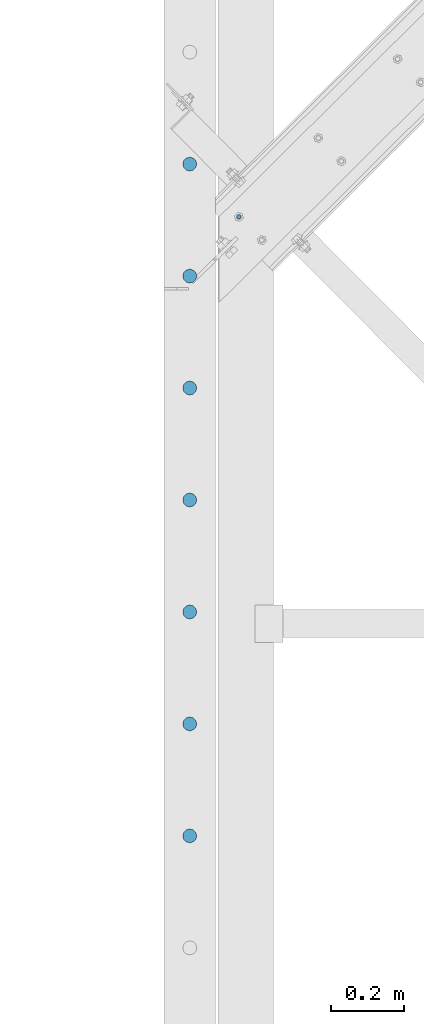
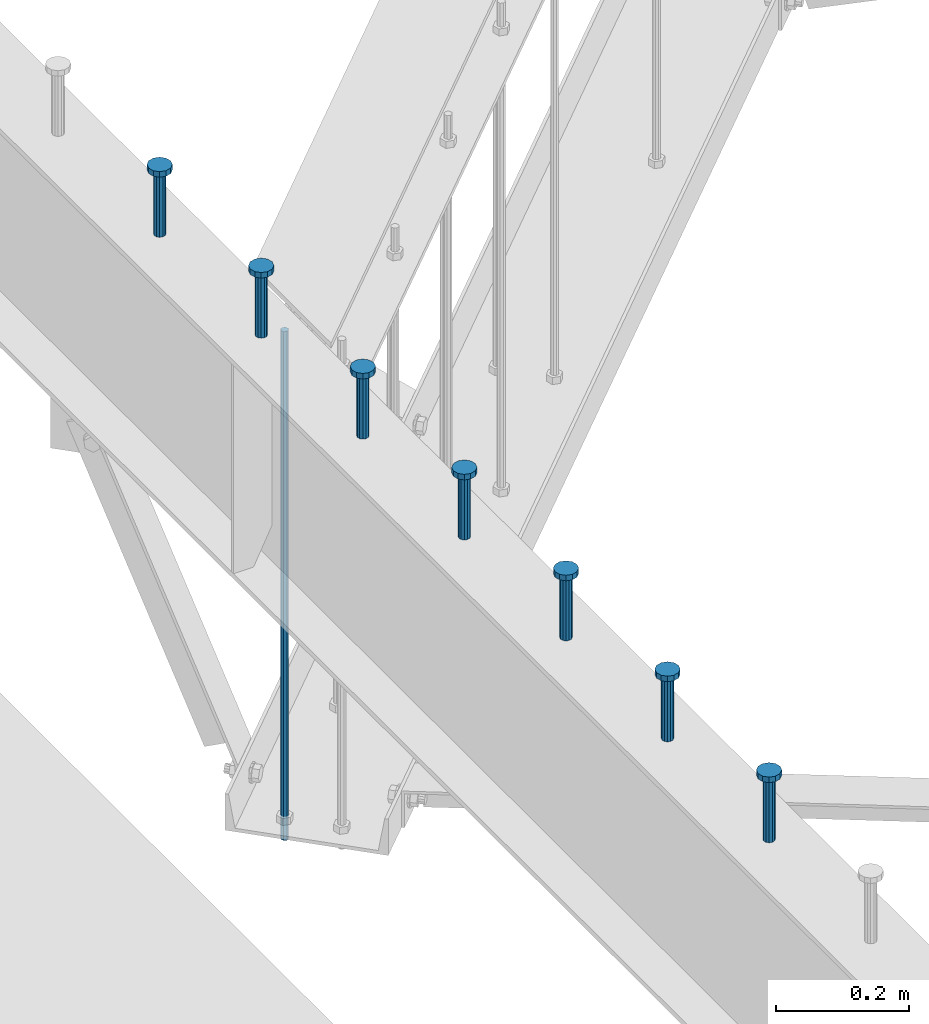
# One storey, part 197 of 975: 8 columns.
"""IFC2X3 building model written with IfcOpenShell, lengths in millimetres."""

from ifc_helpers import new_model, si_unit, frame, origin_with_axes, place, context, subcontext, project, spatial, faceted_brep, material, type_object, element, save


model = new_model("IFC2X3")

# Units and contexts
model_context = context("Model", 3, precision=1e-05, world=origin_with_axes())
body_context = subcontext(model_context, "Body", "Model", "MODEL_VIEW")
ifc_project = project(units=[si_unit("LENGTHUNIT", "METRE", prefix="MILLI"), si_unit("AREAUNIT", "SQUARE_METRE"), si_unit("VOLUMEUNIT", "CUBIC_METRE"), si_unit("MASSUNIT", "GRAM", prefix="KILO"), si_unit("TIMEUNIT", "SECOND"), si_unit("PLANEANGLEUNIT", "RADIAN"), si_unit("SOLIDANGLEUNIT", "STERADIAN"), si_unit("THERMODYNAMICTEMPERATUREUNIT", "DEGREE_CELSIUS"), si_unit("LUMINOUSINTENSITYUNIT", "LUMEN")], contexts=[model_context])

# Site, building, storey
site_placement = place(None, origin_with_axes())
site = spatial("IfcSite", under=ifc_project, at=site_placement, CompositionType="ELEMENT")
building_placement = place(site_placement, origin_with_axes())
building = spatial("IfcBuilding", under=site, at=building_placement, Name="Undefined", CompositionType="ELEMENT")
storey_placement = place(building_placement, origin_with_axes())
storey = spatial("IfcBuildingStorey", under=building, at=storey_placement, Name="Undefined", CompositionType="ELEMENT", Elevation=0.0)

# Columns
ifc_material_1 = material(Name="STEEL/A36")
column_type_1 = type_object("IfcColumnType", PredefinedType="NOTDEFINED")
column_1_placement = place(storey_placement, frame((23704.8451120013, 9911.53748289122, 2870.2), z_axis=(-0.705007718837806, 0.709199630836842, 0.0), x_axis=(0.0, 0.0, 1.0)))
element("IfcColumn", 1, at=column_1_placement, inside=storey, type_object=column_type_1, material=ifc_material_1, Name="ALL-THREAD ROD", context=body_context, shape_type="Brep", body=[
    faceted_brep([(0.0, -6.34999999998763, -3.63797880709171e-12), (0.0, -4.49012806052269, -4.49012806054634), (931.8625, -4.49012806052269, -4.49012806054634), (931.8625, -6.34999999998763, -3.63797880709171e-12), (0.0, 7.27595761418343e-12, -6.35000000000764), (931.8625, 7.27595761418343e-12, -6.35000000000764), (0.0, 4.49012806053724, -4.49012806053906), (931.8625, 4.49012806053724, -4.49012806053906), (0.0, 6.34999999999491, 5.45696821063757e-12), (931.8625, 6.34999999999491, 5.45696821063757e-12), (0.0, 4.49012806052633, 4.49012806054634), (931.8625, 4.49012806052633, 4.49012806054634), (0.0, 0.0, 6.35000000000764), (931.8625, 0.0, 6.35000000000764), (0.0, -4.49012806053361, 4.49012806053543), (931.8625, -4.49012806053361, 4.49012806053543)], [[[0, 1, 2, 3]], [[1, 4, 5, 2]], [[4, 6, 7, 5]], [[6, 8, 9, 7]], [[8, 10, 11, 9]], [[10, 12, 13, 11]], [[12, 14, 15, 13]], [[14, 0, 3, 15]], [[5, 7, 9, 11, 13, 15, 3, 2]], [[14, 12, 10, 8, 6, 4, 1, 0]]]),
])
ifc_material_2 = material(Name="STEEL/A108")
column_type_2 = type_object("IfcColumnType", Name="STUD_3/4-DIA", PredefinedType="NOTDEFINED")
column_2_placement = place(storey_placement, frame((23571.2662714101, 10055.225, 3937.0), z_axis=(0.0, 1.0, 0.0), x_axis=(0.0, 0.0, 1.0)))
element("IfcColumn", 2, at=column_2_placement, inside=storey, type_object=column_type_2, material=ifc_material_2, ObjectType="STUD_3/4-DIA", context=body_context, shape_type="Brep", body=[
    faceted_brep([(0.0, -9.52000045776367, 0.0), (0.0, -8.25, -4.76000022888184), (115.57, -8.25, -4.76000022888184), (115.57, -9.52000045776367, 0.0), (0.0, -4.76000022888184, -8.25), (115.57, -4.76000022888184, -8.25), (0.0, 0.0, -9.52000045776367), (115.57, 0.0, -9.52000045776367), (0.0, 4.76000022888184, -8.25), (115.57, 4.76000022888184, -8.25), (0.0, 8.25, -4.76000022888184), (115.57, 8.25, -4.76000022888184), (0.0, 9.52000045776367, 0.0), (115.57, 9.52000045776367, 0.0), (0.0, 8.25, 4.76000022888184), (115.57, 8.25, 4.76000022888184), (0.0, 4.76000022888184, 8.25), (115.57, 4.76000022888184, 8.25), (0.0, 0.0, 9.52000045776367), (115.57, 0.0, 9.52000045776367), (0.0, -4.76000022888184, 8.25), (115.57, -4.76000022888184, 8.25), (0.0, -8.25, 4.76000022888184), (115.57, -8.25, 4.76000022888184), (116.84, -16.5, -9.52000045776367), (116.84, -19.0499992370605, 0.0), (116.84, -9.52000045776367, -16.5), (116.84, 0.0, -19.0499992370605), (116.84, 9.52000045776367, -16.5), (116.84, 16.5, -9.52000045776367), (116.84, 19.0499992370605, 0.0), (116.84, 16.5, 9.52000045776367), (116.84, 9.52000045776367, 16.5), (116.84, 0.0, 19.0499992370605), (116.84, -9.52000045776367, 16.5), (116.84, -16.5, 9.52000045776367), (127.0, -16.5, -9.52000045776367), (127.0, -19.0499992370605, 0.0), (127.0, -9.52000045776367, -16.5), (127.0, 0.0, -19.0499992370605), (127.0, 9.52000045776367, -16.5), (127.0, 16.5, -9.52000045776367), (127.0, 19.0499992370605, 0.0), (127.0, 16.5, 9.52000045776367), (127.0, 9.52000045776367, 16.5), (127.0, 0.0, 19.0499992370605), (127.0, -9.52000045776367, 16.5), (127.0, -16.5, 9.52000045776367)], [[[0, 1, 2, 3]], [[1, 4, 5, 2]], [[4, 6, 7, 5]], [[6, 8, 9, 7]], [[8, 10, 11, 9]], [[10, 12, 13, 11]], [[12, 14, 15, 13]], [[14, 16, 17, 15]], [[16, 18, 19, 17]], [[18, 20, 21, 19]], [[20, 22, 23, 21]], [[22, 0, 3, 23]], [[22, 20, 18, 16, 14, 12, 10, 8, 6, 4, 1, 0]], [[3, 2, 24, 25]], [[2, 5, 26, 24]], [[5, 7, 27, 26]], [[7, 9, 28, 27]], [[9, 11, 29, 28]], [[11, 13, 30, 29]], [[13, 15, 31, 30]], [[15, 17, 32, 31]], [[17, 19, 33, 32]], [[19, 21, 34, 33]], [[21, 23, 35, 34]], [[23, 3, 25, 35]], [[25, 24, 36, 37]], [[24, 26, 38, 36]], [[26, 27, 39, 38]], [[27, 28, 40, 39]], [[28, 29, 41, 40]], [[29, 30, 42, 41]], [[30, 31, 43, 42]], [[31, 32, 44, 43]], [[32, 33, 45, 44]], [[33, 34, 46, 45]], [[34, 35, 47, 46]], [[35, 25, 37, 47]], [[38, 39, 40, 41, 42, 43, 44, 45, 46, 47, 37, 36]]]),
])
column_3_placement = place(storey_placement, frame((23571.2662714101, 9750.425, 3937.0), z_axis=(0.0, 1.0, 0.0), x_axis=(0.0, 0.0, 1.0)))
element("IfcColumn", 3, at=column_3_placement, inside=storey, type_object=column_type_2, material=ifc_material_2, ObjectType="STUD_3/4-DIA", context=body_context, shape_type="Brep", body=[
    faceted_brep([(0.0, -9.52000045776367, 0.0), (0.0, -8.25, -4.76000022888184), (115.57, -8.25, -4.76000022888184), (115.57, -9.52000045776367, 0.0), (0.0, -4.76000022888184, -8.25), (115.57, -4.76000022888184, -8.25), (0.0, 0.0, -9.52000045776367), (115.57, 0.0, -9.52000045776367), (0.0, 4.76000022888184, -8.25), (115.57, 4.76000022888184, -8.25), (0.0, 8.25, -4.76000022888184), (115.57, 8.25, -4.76000022888184), (0.0, 9.52000045776367, 0.0), (115.57, 9.52000045776367, 0.0), (0.0, 8.25, 4.76000022888184), (115.57, 8.25, 4.76000022888184), (0.0, 4.76000022888184, 8.25), (115.57, 4.76000022888184, 8.25), (0.0, 0.0, 9.52000045776367), (115.57, 0.0, 9.52000045776367), (0.0, -4.76000022888184, 8.25), (115.57, -4.76000022888184, 8.25), (0.0, -8.25, 4.76000022888184), (115.57, -8.25, 4.76000022888184), (116.84, -16.5, -9.52000045776367), (116.84, -19.0499992370605, 0.0), (116.84, -9.52000045776367, -16.5), (116.84, 0.0, -19.0499992370605), (116.84, 9.52000045776367, -16.5), (116.84, 16.5, -9.52000045776367), (116.84, 19.0499992370605, 0.0), (116.84, 16.5, 9.52000045776367), (116.84, 9.52000045776367, 16.5), (116.84, 0.0, 19.0499992370605), (116.84, -9.52000045776367, 16.5), (116.84, -16.5, 9.52000045776367), (127.0, -16.5, -9.52000045776367), (127.0, -19.0499992370605, 0.0), (127.0, -9.52000045776367, -16.5), (127.0, 0.0, -19.0499992370605), (127.0, 9.52000045776367, -16.5), (127.0, 16.5, -9.52000045776367), (127.0, 19.0499992370605, 0.0), (127.0, 16.5, 9.52000045776367), (127.0, 9.52000045776367, 16.5), (127.0, 0.0, 19.0499992370605), (127.0, -9.52000045776367, 16.5), (127.0, -16.5, 9.52000045776367)], [[[0, 1, 2, 3]], [[1, 4, 5, 2]], [[4, 6, 7, 5]], [[6, 8, 9, 7]], [[8, 10, 11, 9]], [[10, 12, 13, 11]], [[12, 14, 15, 13]], [[14, 16, 17, 15]], [[16, 18, 19, 17]], [[18, 20, 21, 19]], [[20, 22, 23, 21]], [[22, 0, 3, 23]], [[22, 20, 18, 16, 14, 12, 10, 8, 6, 4, 1, 0]], [[3, 2, 24, 25]], [[2, 5, 26, 24]], [[5, 7, 27, 26]], [[7, 9, 28, 27]], [[9, 11, 29, 28]], [[11, 13, 30, 29]], [[13, 15, 31, 30]], [[15, 17, 32, 31]], [[17, 19, 33, 32]], [[19, 21, 34, 33]], [[21, 23, 35, 34]], [[23, 3, 25, 35]], [[25, 24, 36, 37]], [[24, 26, 38, 36]], [[26, 27, 39, 38]], [[27, 28, 40, 39]], [[28, 29, 41, 40]], [[29, 30, 42, 41]], [[30, 31, 43, 42]], [[31, 32, 44, 43]], [[32, 33, 45, 44]], [[33, 34, 46, 45]], [[34, 35, 47, 46]], [[35, 25, 37, 47]], [[38, 39, 40, 41, 42, 43, 44, 45, 46, 47, 37, 36]]]),
])
column_4_placement = place(storey_placement, frame((23571.2662714101, 9445.625, 3937.0), z_axis=(0.0, 1.0, 0.0), x_axis=(0.0, 0.0, 1.0)))
element("IfcColumn", 4, at=column_4_placement, inside=storey, type_object=column_type_2, material=ifc_material_2, ObjectType="STUD_3/4-DIA", context=body_context, shape_type="Brep", body=[
    faceted_brep([(0.0, -9.52000045776367, 0.0), (0.0, -8.25, -4.76000022888184), (115.57, -8.25, -4.76000022888184), (115.57, -9.52000045776367, 0.0), (0.0, -4.76000022888184, -8.25), (115.57, -4.76000022888184, -8.25), (0.0, 0.0, -9.52000045776367), (115.57, 0.0, -9.52000045776367), (0.0, 4.76000022888184, -8.25), (115.57, 4.76000022888184, -8.25), (0.0, 8.25, -4.76000022888184), (115.57, 8.25, -4.76000022888184), (0.0, 9.52000045776367, 0.0), (115.57, 9.52000045776367, 0.0), (0.0, 8.25, 4.76000022888184), (115.57, 8.25, 4.76000022888184), (0.0, 4.76000022888184, 8.25), (115.57, 4.76000022888184, 8.25), (0.0, 0.0, 9.52000045776367), (115.57, 0.0, 9.52000045776367), (0.0, -4.76000022888184, 8.25), (115.57, -4.76000022888184, 8.25), (0.0, -8.25, 4.76000022888184), (115.57, -8.25, 4.76000022888184), (116.84, -16.5, -9.52000045776367), (116.84, -19.0499992370605, 0.0), (116.84, -9.52000045776367, -16.5), (116.84, 0.0, -19.0499992370605), (116.84, 9.52000045776367, -16.5), (116.84, 16.5, -9.52000045776367), (116.84, 19.0499992370605, 0.0), (116.84, 16.5, 9.52000045776367), (116.84, 9.52000045776367, 16.5), (116.84, 0.0, 19.0499992370605), (116.84, -9.52000045776367, 16.5), (116.84, -16.5, 9.52000045776367), (127.0, -16.5, -9.52000045776367), (127.0, -19.0499992370605, 0.0), (127.0, -9.52000045776367, -16.5), (127.0, 0.0, -19.0499992370605), (127.0, 9.52000045776367, -16.5), (127.0, 16.5, -9.52000045776367), (127.0, 19.0499992370605, 0.0), (127.0, 16.5, 9.52000045776367), (127.0, 9.52000045776367, 16.5), (127.0, 0.0, 19.0499992370605), (127.0, -9.52000045776367, 16.5), (127.0, -16.5, 9.52000045776367)], [[[0, 1, 2, 3]], [[1, 4, 5, 2]], [[4, 6, 7, 5]], [[6, 8, 9, 7]], [[8, 10, 11, 9]], [[10, 12, 13, 11]], [[12, 14, 15, 13]], [[14, 16, 17, 15]], [[16, 18, 19, 17]], [[18, 20, 21, 19]], [[20, 22, 23, 21]], [[22, 0, 3, 23]], [[22, 20, 18, 16, 14, 12, 10, 8, 6, 4, 1, 0]], [[3, 2, 24, 25]], [[2, 5, 26, 24]], [[5, 7, 27, 26]], [[7, 9, 28, 27]], [[9, 11, 29, 28]], [[11, 13, 30, 29]], [[13, 15, 31, 30]], [[15, 17, 32, 31]], [[17, 19, 33, 32]], [[19, 21, 34, 33]], [[21, 23, 35, 34]], [[23, 3, 25, 35]], [[25, 24, 36, 37]], [[24, 26, 38, 36]], [[26, 27, 39, 38]], [[27, 28, 40, 39]], [[28, 29, 41, 40]], [[29, 30, 42, 41]], [[30, 31, 43, 42]], [[31, 32, 44, 43]], [[32, 33, 45, 44]], [[33, 34, 46, 45]], [[34, 35, 47, 46]], [[35, 25, 37, 47]], [[38, 39, 40, 41, 42, 43, 44, 45, 46, 47, 37, 36]]]),
])
column_5_placement = place(storey_placement, frame((23571.2662714101, 9140.825, 3937.0), z_axis=(0.0, 1.0, 0.0), x_axis=(0.0, 0.0, 1.0)))
element("IfcColumn", 5, at=column_5_placement, inside=storey, type_object=column_type_2, material=ifc_material_2, ObjectType="STUD_3/4-DIA", context=body_context, shape_type="Brep", body=[
    faceted_brep([(0.0, -9.52000045776367, 0.0), (0.0, -8.25, -4.76000022888184), (115.57, -8.25, -4.76000022888184), (115.57, -9.52000045776367, 0.0), (0.0, -4.76000022888184, -8.25), (115.57, -4.76000022888184, -8.25), (0.0, 0.0, -9.52000045776367), (115.57, 0.0, -9.52000045776367), (0.0, 4.76000022888184, -8.25), (115.57, 4.76000022888184, -8.25), (0.0, 8.25, -4.76000022888184), (115.57, 8.25, -4.76000022888184), (0.0, 9.52000045776367, 0.0), (115.57, 9.52000045776367, 0.0), (0.0, 8.25, 4.76000022888184), (115.57, 8.25, 4.76000022888184), (0.0, 4.76000022888184, 8.25), (115.57, 4.76000022888184, 8.25), (0.0, 0.0, 9.52000045776367), (115.57, 0.0, 9.52000045776367), (0.0, -4.76000022888184, 8.25), (115.57, -4.76000022888184, 8.25), (0.0, -8.25, 4.76000022888184), (115.57, -8.25, 4.76000022888184), (116.84, -16.5, -9.52000045776367), (116.84, -19.0499992370605, 0.0), (116.84, -9.52000045776367, -16.5), (116.84, 0.0, -19.0499992370605), (116.84, 9.52000045776367, -16.5), (116.84, 16.5, -9.52000045776367), (116.84, 19.0499992370605, 0.0), (116.84, 16.5, 9.52000045776367), (116.84, 9.52000045776367, 16.5), (116.84, 0.0, 19.0499992370605), (116.84, -9.52000045776367, 16.5), (116.84, -16.5, 9.52000045776367), (127.0, -16.5, -9.52000045776367), (127.0, -19.0499992370605, 0.0), (127.0, -9.52000045776367, -16.5), (127.0, 0.0, -19.0499992370605), (127.0, 9.52000045776367, -16.5), (127.0, 16.5, -9.52000045776367), (127.0, 19.0499992370605, 0.0), (127.0, 16.5, 9.52000045776367), (127.0, 9.52000045776367, 16.5), (127.0, 0.0, 19.0499992370605), (127.0, -9.52000045776367, 16.5), (127.0, -16.5, 9.52000045776367)], [[[0, 1, 2, 3]], [[1, 4, 5, 2]], [[4, 6, 7, 5]], [[6, 8, 9, 7]], [[8, 10, 11, 9]], [[10, 12, 13, 11]], [[12, 14, 15, 13]], [[14, 16, 17, 15]], [[16, 18, 19, 17]], [[18, 20, 21, 19]], [[20, 22, 23, 21]], [[22, 0, 3, 23]], [[22, 20, 18, 16, 14, 12, 10, 8, 6, 4, 1, 0]], [[3, 2, 24, 25]], [[2, 5, 26, 24]], [[5, 7, 27, 26]], [[7, 9, 28, 27]], [[9, 11, 29, 28]], [[11, 13, 30, 29]], [[13, 15, 31, 30]], [[15, 17, 32, 31]], [[17, 19, 33, 32]], [[19, 21, 34, 33]], [[21, 23, 35, 34]], [[23, 3, 25, 35]], [[25, 24, 36, 37]], [[24, 26, 38, 36]], [[26, 27, 39, 38]], [[27, 28, 40, 39]], [[28, 29, 41, 40]], [[29, 30, 42, 41]], [[30, 31, 43, 42]], [[31, 32, 44, 43]], [[32, 33, 45, 44]], [[33, 34, 46, 45]], [[34, 35, 47, 46]], [[35, 25, 37, 47]], [[38, 39, 40, 41, 42, 43, 44, 45, 46, 47, 37, 36]]]),
])
column_6_placement = place(storey_placement, frame((23571.2662714101, 8836.025, 3937.0), z_axis=(0.0, 1.0, 0.0), x_axis=(0.0, 0.0, 1.0)))
element("IfcColumn", 6, at=column_6_placement, inside=storey, type_object=column_type_2, material=ifc_material_2, ObjectType="STUD_3/4-DIA", context=body_context, shape_type="Brep", body=[
    faceted_brep([(0.0, -9.52000045776367, 0.0), (0.0, -8.25, -4.76000022888184), (115.57, -8.25, -4.76000022888184), (115.57, -9.52000045776367, 0.0), (0.0, -4.76000022888184, -8.25), (115.57, -4.76000022888184, -8.25), (0.0, 0.0, -9.52000045776367), (115.57, 0.0, -9.52000045776367), (0.0, 4.76000022888184, -8.25), (115.57, 4.76000022888184, -8.25), (0.0, 8.25, -4.76000022888184), (115.57, 8.25, -4.76000022888184), (0.0, 9.52000045776367, 0.0), (115.57, 9.52000045776367, 0.0), (0.0, 8.25, 4.76000022888184), (115.57, 8.25, 4.76000022888184), (0.0, 4.76000022888184, 8.25), (115.57, 4.76000022888184, 8.25), (0.0, 0.0, 9.52000045776367), (115.57, 0.0, 9.52000045776367), (0.0, -4.76000022888184, 8.25), (115.57, -4.76000022888184, 8.25), (0.0, -8.25, 4.76000022888184), (115.57, -8.25, 4.76000022888184), (116.84, -16.5, -9.52000045776367), (116.84, -19.0499992370605, 0.0), (116.84, -9.52000045776367, -16.5), (116.84, 0.0, -19.0499992370605), (116.84, 9.52000045776367, -16.5), (116.84, 16.5, -9.52000045776367), (116.84, 19.0499992370605, 0.0), (116.84, 16.5, 9.52000045776367), (116.84, 9.52000045776367, 16.5), (116.84, 0.0, 19.0499992370605), (116.84, -9.52000045776367, 16.5), (116.84, -16.5, 9.52000045776367), (127.0, -16.5, -9.52000045776367), (127.0, -19.0499992370605, 0.0), (127.0, -9.52000045776367, -16.5), (127.0, 0.0, -19.0499992370605), (127.0, 9.52000045776367, -16.5), (127.0, 16.5, -9.52000045776367), (127.0, 19.0499992370605, 0.0), (127.0, 16.5, 9.52000045776367), (127.0, 9.52000045776367, 16.5), (127.0, 0.0, 19.0499992370605), (127.0, -9.52000045776367, 16.5), (127.0, -16.5, 9.52000045776367)], [[[0, 1, 2, 3]], [[1, 4, 5, 2]], [[4, 6, 7, 5]], [[6, 8, 9, 7]], [[8, 10, 11, 9]], [[10, 12, 13, 11]], [[12, 14, 15, 13]], [[14, 16, 17, 15]], [[16, 18, 19, 17]], [[18, 20, 21, 19]], [[20, 22, 23, 21]], [[22, 0, 3, 23]], [[22, 20, 18, 16, 14, 12, 10, 8, 6, 4, 1, 0]], [[3, 2, 24, 25]], [[2, 5, 26, 24]], [[5, 7, 27, 26]], [[7, 9, 28, 27]], [[9, 11, 29, 28]], [[11, 13, 30, 29]], [[13, 15, 31, 30]], [[15, 17, 32, 31]], [[17, 19, 33, 32]], [[19, 21, 34, 33]], [[21, 23, 35, 34]], [[23, 3, 25, 35]], [[25, 24, 36, 37]], [[24, 26, 38, 36]], [[26, 27, 39, 38]], [[27, 28, 40, 39]], [[28, 29, 41, 40]], [[29, 30, 42, 41]], [[30, 31, 43, 42]], [[31, 32, 44, 43]], [[32, 33, 45, 44]], [[33, 34, 46, 45]], [[34, 35, 47, 46]], [[35, 25, 37, 47]], [[38, 39, 40, 41, 42, 43, 44, 45, 46, 47, 37, 36]]]),
])
column_7_placement = place(storey_placement, frame((23571.2662714101, 8531.225, 3937.0), z_axis=(0.0, 1.0, 0.0), x_axis=(0.0, 0.0, 1.0)))
element("IfcColumn", 7, at=column_7_placement, inside=storey, type_object=column_type_2, material=ifc_material_2, ObjectType="STUD_3/4-DIA", context=body_context, shape_type="Brep", body=[
    faceted_brep([(0.0, -9.52000045776367, 0.0), (0.0, -8.25, -4.76000022888184), (115.57, -8.25, -4.76000022888184), (115.57, -9.52000045776367, 0.0), (0.0, -4.76000022888184, -8.25), (115.57, -4.76000022888184, -8.25), (0.0, 0.0, -9.52000045776367), (115.57, 0.0, -9.52000045776367), (0.0, 4.76000022888184, -8.25), (115.57, 4.76000022888184, -8.25), (0.0, 8.25, -4.76000022888184), (115.57, 8.25, -4.76000022888184), (0.0, 9.52000045776367, 0.0), (115.57, 9.52000045776367, 0.0), (0.0, 8.25, 4.76000022888184), (115.57, 8.25, 4.76000022888184), (0.0, 4.76000022888184, 8.25), (115.57, 4.76000022888184, 8.25), (0.0, 0.0, 9.52000045776367), (115.57, 0.0, 9.52000045776367), (0.0, -4.76000022888184, 8.25), (115.57, -4.76000022888184, 8.25), (0.0, -8.25, 4.76000022888184), (115.57, -8.25, 4.76000022888184), (116.84, -16.5, -9.52000045776367), (116.84, -19.0499992370605, 0.0), (116.84, -9.52000045776367, -16.5), (116.84, 0.0, -19.0499992370605), (116.84, 9.52000045776367, -16.5), (116.84, 16.5, -9.52000045776367), (116.84, 19.0499992370605, 0.0), (116.84, 16.5, 9.52000045776367), (116.84, 9.52000045776367, 16.5), (116.84, 0.0, 19.0499992370605), (116.84, -9.52000045776367, 16.5), (116.84, -16.5, 9.52000045776367), (127.0, -16.5, -9.52000045776367), (127.0, -19.0499992370605, 0.0), (127.0, -9.52000045776367, -16.5), (127.0, 0.0, -19.0499992370605), (127.0, 9.52000045776367, -16.5), (127.0, 16.5, -9.52000045776367), (127.0, 19.0499992370605, 0.0), (127.0, 16.5, 9.52000045776367), (127.0, 9.52000045776367, 16.5), (127.0, 0.0, 19.0499992370605), (127.0, -9.52000045776367, 16.5), (127.0, -16.5, 9.52000045776367)], [[[0, 1, 2, 3]], [[1, 4, 5, 2]], [[4, 6, 7, 5]], [[6, 8, 9, 7]], [[8, 10, 11, 9]], [[10, 12, 13, 11]], [[12, 14, 15, 13]], [[14, 16, 17, 15]], [[16, 18, 19, 17]], [[18, 20, 21, 19]], [[20, 22, 23, 21]], [[22, 0, 3, 23]], [[22, 20, 18, 16, 14, 12, 10, 8, 6, 4, 1, 0]], [[3, 2, 24, 25]], [[2, 5, 26, 24]], [[5, 7, 27, 26]], [[7, 9, 28, 27]], [[9, 11, 29, 28]], [[11, 13, 30, 29]], [[13, 15, 31, 30]], [[15, 17, 32, 31]], [[17, 19, 33, 32]], [[19, 21, 34, 33]], [[21, 23, 35, 34]], [[23, 3, 25, 35]], [[25, 24, 36, 37]], [[24, 26, 38, 36]], [[26, 27, 39, 38]], [[27, 28, 40, 39]], [[28, 29, 41, 40]], [[29, 30, 42, 41]], [[30, 31, 43, 42]], [[31, 32, 44, 43]], [[32, 33, 45, 44]], [[33, 34, 46, 45]], [[34, 35, 47, 46]], [[35, 25, 37, 47]], [[38, 39, 40, 41, 42, 43, 44, 45, 46, 47, 37, 36]]]),
])
column_8_placement = place(storey_placement, frame((23571.2662714101, 8226.425, 3937.0), z_axis=(0.0, 1.0, 0.0), x_axis=(0.0, 0.0, 1.0)))
element("IfcColumn", 8, at=column_8_placement, inside=storey, type_object=column_type_2, material=ifc_material_2, ObjectType="STUD_3/4-DIA", context=body_context, shape_type="Brep", body=[
    faceted_brep([(0.0, -9.52000045776367, 0.0), (0.0, -8.25, -4.76000022888184), (115.57, -8.25, -4.76000022888184), (115.57, -9.52000045776367, 0.0), (0.0, -4.76000022888184, -8.25), (115.57, -4.76000022888184, -8.25), (0.0, 0.0, -9.52000045776367), (115.57, 0.0, -9.52000045776367), (0.0, 4.76000022888184, -8.25), (115.57, 4.76000022888184, -8.25), (0.0, 8.25, -4.76000022888184), (115.57, 8.25, -4.76000022888184), (0.0, 9.52000045776367, 0.0), (115.57, 9.52000045776367, 0.0), (0.0, 8.25, 4.76000022888184), (115.57, 8.25, 4.76000022888184), (0.0, 4.76000022888184, 8.25), (115.57, 4.76000022888184, 8.25), (0.0, 0.0, 9.52000045776367), (115.57, 0.0, 9.52000045776367), (0.0, -4.76000022888184, 8.25), (115.57, -4.76000022888184, 8.25), (0.0, -8.25, 4.76000022888184), (115.57, -8.25, 4.76000022888184), (116.84, -16.5, -9.52000045776367), (116.84, -19.0499992370605, 0.0), (116.84, -9.52000045776367, -16.5), (116.84, 0.0, -19.0499992370605), (116.84, 9.52000045776367, -16.5), (116.84, 16.5, -9.52000045776367), (116.84, 19.0499992370605, 0.0), (116.84, 16.5, 9.52000045776367), (116.84, 9.52000045776367, 16.5), (116.84, 0.0, 19.0499992370605), (116.84, -9.52000045776367, 16.5), (116.84, -16.5, 9.52000045776367), (127.0, -16.5, -9.52000045776367), (127.0, -19.0499992370605, 0.0), (127.0, -9.52000045776367, -16.5), (127.0, 0.0, -19.0499992370605), (127.0, 9.52000045776367, -16.5), (127.0, 16.5, -9.52000045776367), (127.0, 19.0499992370605, 0.0), (127.0, 16.5, 9.52000045776367), (127.0, 9.52000045776367, 16.5), (127.0, 0.0, 19.0499992370605), (127.0, -9.52000045776367, 16.5), (127.0, -16.5, 9.52000045776367)], [[[0, 1, 2, 3]], [[1, 4, 5, 2]], [[4, 6, 7, 5]], [[6, 8, 9, 7]], [[8, 10, 11, 9]], [[10, 12, 13, 11]], [[12, 14, 15, 13]], [[14, 16, 17, 15]], [[16, 18, 19, 17]], [[18, 20, 21, 19]], [[20, 22, 23, 21]], [[22, 0, 3, 23]], [[22, 20, 18, 16, 14, 12, 10, 8, 6, 4, 1, 0]], [[3, 2, 24, 25]], [[2, 5, 26, 24]], [[5, 7, 27, 26]], [[7, 9, 28, 27]], [[9, 11, 29, 28]], [[11, 13, 30, 29]], [[13, 15, 31, 30]], [[15, 17, 32, 31]], [[17, 19, 33, 32]], [[19, 21, 34, 33]], [[21, 23, 35, 34]], [[23, 3, 25, 35]], [[25, 24, 36, 37]], [[24, 26, 38, 36]], [[26, 27, 39, 38]], [[27, 28, 40, 39]], [[28, 29, 41, 40]], [[29, 30, 42, 41]], [[30, 31, 43, 42]], [[31, 32, 44, 43]], [[32, 33, 45, 44]], [[33, 34, 46, 45]], [[34, 35, 47, 46]], [[35, 25, 37, 47]], [[38, 39, 40, 41, 42, 43, 44, 45, 46, 47, 37, 36]]]),
])

save(model, "model.ifc")
